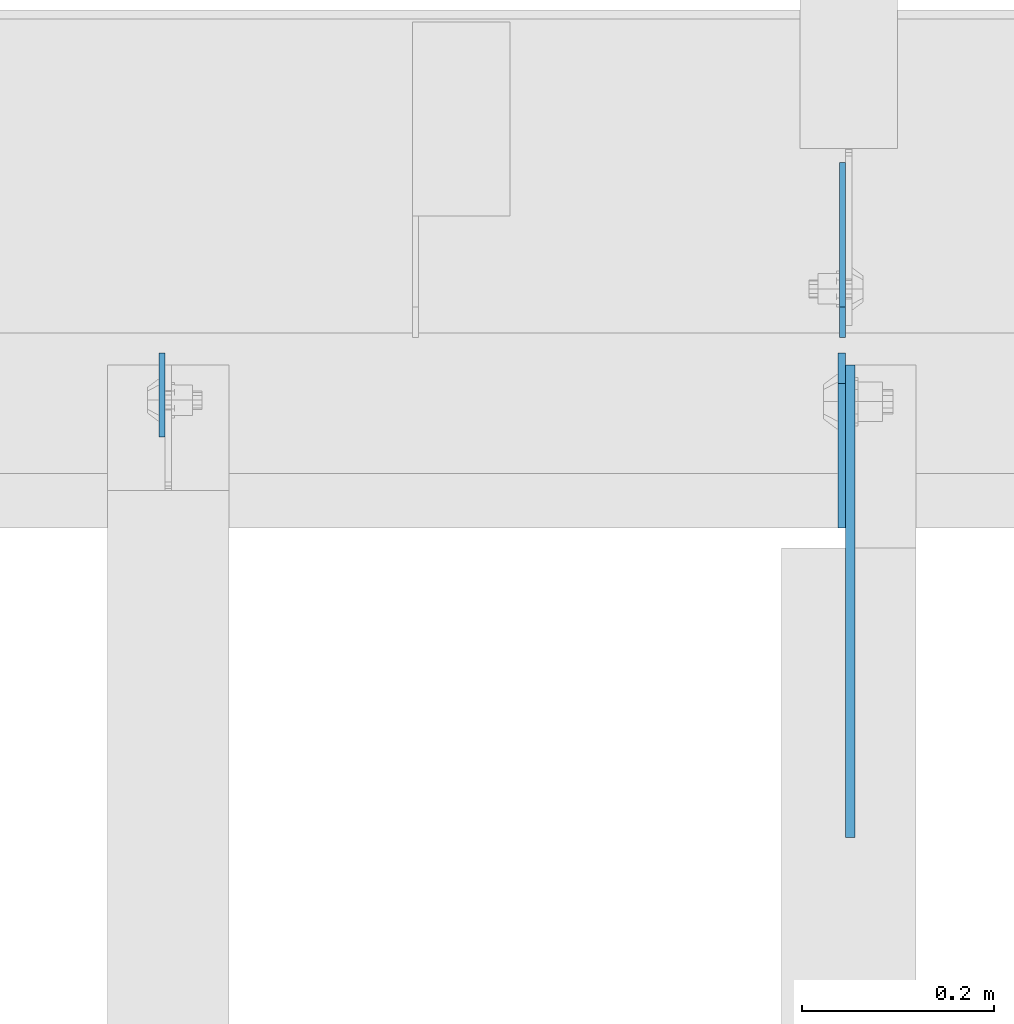
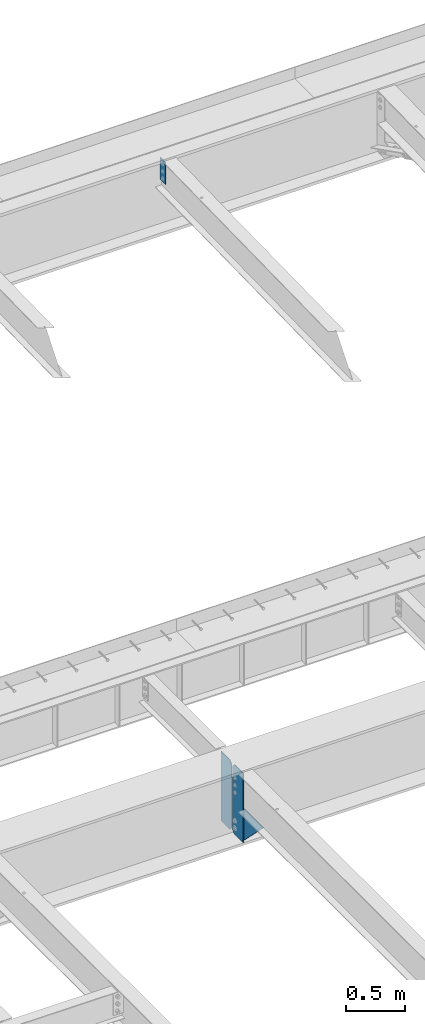
# One storey, part 1598 of 1763: 4 plates, 3 elements without a shape of their own.
"""IFC2X3 building model written with IfcOpenShell, lengths in millimetres."""

from ifc_helpers import new_model, si_unit, frame, origin_with_axes, place, context, subcontext, project, spatial, faceted_brep, material, type_object, element, aggregate, save


model = new_model("IFC2X3")

# Units and contexts
model_context = context("Model", 3, precision=1e-05, world=origin_with_axes())
body_context = subcontext(model_context, "Body", "Model", "MODEL_VIEW")
ifc_project = project(units=[si_unit("LENGTHUNIT", "METRE", prefix="MILLI"), si_unit("AREAUNIT", "SQUARE_METRE"), si_unit("VOLUMEUNIT", "CUBIC_METRE"), si_unit("MASSUNIT", "GRAM", prefix="KILO"), si_unit("TIMEUNIT", "SECOND"), si_unit("PLANEANGLEUNIT", "RADIAN"), si_unit("SOLIDANGLEUNIT", "STERADIAN"), si_unit("THERMODYNAMICTEMPERATUREUNIT", "DEGREE_CELSIUS"), si_unit("LUMINOUSINTENSITYUNIT", "LUMEN")], contexts=[model_context])

# Site, building, storey
site_placement = place(None, origin_with_axes())
site = spatial("IfcSite", under=ifc_project, at=site_placement, CompositionType="ELEMENT")
building_placement = place(site_placement, origin_with_axes())
building = spatial("IfcBuilding", under=site, at=building_placement, Name="Undefined", CompositionType="ELEMENT")
storey_placement = place(building_placement, origin_with_axes())
storey = spatial("IfcBuildingStorey", under=building, at=storey_placement, Name="Undefined", CompositionType="ELEMENT", Elevation=0.0)

# Assembly, plates
assembly_1_placement = place(storey_placement, origin_with_axes())
assembly_1 = element("IfcElementAssembly", 1, at=assembly_1_placement, inside=storey, Name="BEAM", AssemblyPlace="NOTDEFINED", PredefinedType="RIGID_FRAME")
ifc_material = material(Name="STEEL/A36")
plate_type_1 = type_object("IfcPlateType", PredefinedType="NOTDEFINED")
plate_1_placement = place(assembly_1_placement, frame((-82420.3206070794, 52128.7375, 4448.175), z_axis=(0.0, 0.0, 1.0), x_axis=(0.0, 1.0, 0.0)))
plate_1 = element("IfcPlate", 2, at=plate_1_placement, type_object=plate_type_1, material=ifc_material, Name="PLATE", context=body_context, shape_type="Brep", body=[
    faceted_brep([(0.0, -3.17500000000291, 31.75), (0.0, -3.17500000000291, 687.387512207031), (0.0, 3.17500000000291, 687.387512207031), (0.0, 3.17500000000291, 31.75), (31.75, -3.17500000000291, 719.137512207031), (31.75, 3.17500000000291, 719.137512207031), (182.5625, -3.17500000000291, 719.137512207031), (182.5625, 3.17500000000291, 719.137512207031), (182.5625, -3.17500000000291, 0.0), (182.5625, 3.17500000000291, 0.0), (31.7499999999036, -3.17499999997381, 9.42916855706244e-11), (31.7499999998854, 3.17500000000291, 9.42916855706244e-11)], [[[0, 1, 2, 3]], [[1, 4, 5, 2]], [[4, 6, 7, 5]], [[6, 8, 9, 7]], [[8, 10, 11, 9]], [[10, 0, 3, 11]], [[5, 7, 9, 11, 3, 2]], [[10, 8, 6, 4, 1, 0]]]),
])
plate_type_2 = type_object("IfcPlateType", PredefinedType="NOTDEFINED")
plate_2_placement = place(assembly_1_placement, frame((-82421.1153570965, 52112.8625, 4448.175), z_axis=(0.0, 0.0, 1.0), x_axis=(0.0, -1.0, 0.0)))
plate_2 = element("IfcPlate", 3, at=plate_2_placement, type_object=plate_type_2, material=ifc_material, Name="PLATE", context=body_context, shape_type="Brep", body=[
    faceted_brep([(0.0, -3.96899999999732, 31.75), (0.0, -3.96899999999732, 687.387512207031), (0.0, 3.96899999999732, 687.387512207031), (0.0, 3.96899999999732, 31.75), (31.75, -3.96899999999732, 719.137512207031), (31.75, 3.96899999999732, 719.137512207031), (182.5625, -3.96899999999732, 719.137512207031), (182.5625, 3.96899999999732, 719.137512207031), (182.5625, -3.96899999999732, 0.0), (182.5625, 3.96899999999732, 0.0), (31.75, -3.96899999999732, 0.0), (31.75, 3.96899999999732, 0.0)], [[[0, 1, 2, 3]], [[1, 4, 5, 2]], [[4, 6, 7, 5]], [[6, 8, 9, 7]], [[8, 10, 11, 9]], [[10, 0, 3, 11]], [[5, 7, 9, 11, 3, 2]], [[10, 8, 6, 4, 1, 0]]]),
])
aggregate(assembly_1, [plate_1, plate_2])

# Assembly, plate
assembly_2_placement = place(storey_placement, origin_with_axes())
assembly_2 = element("IfcElementAssembly", 4, at=assembly_2_placement, inside=storey, Name="BEAM", AssemblyPlace="NOTDEFINED", PredefinedType="RIGID_FRAME")
plate_type_3 = type_object("IfcPlateType", PredefinedType="NOTDEFINED")
plate_3_placement = place(assembly_2_placement, frame((-82412.3831070794, 51930.3004272461, 4794.2499684514), z_axis=(0.0, 0.0, -1.0), x_axis=(0.0, -1.0, 0.0)))
plate_3 = element("IfcPlate", 5, at=plate_3_placement, type_object=plate_type_3, material=ifc_material, Name="PLATE", context=body_context, shape_type="Brep", body=[
    faceted_brep([(0.0, -4.76249999999982, 0.0), (-169.862075805664, -4.76249999999709, 6.30279828328639e-10), (-169.862075805664, 4.76249999999709, 6.30279828328639e-10), (0.0, 4.76249999999982, 0.0), (-169.862091064453, -4.76249999999709, 323.002471923828), (-169.862091064453, 4.76249999999709, 323.002471923828), (6.38101482763886e-09, -4.76249999999709, 323.002471923828), (6.38101482763886e-09, 4.76249999999709, 323.002471923828), (322.262145996094, -4.76249999999709, -1.15778675535694e-09), (322.262145996094, 4.76249999999709, -1.15778675535694e-09)], [[[0, 1, 2, 3]], [[1, 4, 5, 2]], [[4, 6, 7, 5]], [[6, 8, 9, 7]], [[8, 0, 3, 9]], [[5, 7, 9, 3, 2]], [[8, 6, 4, 1, 0]]]),
])
aggregate(assembly_2, [plate_3])

assembly_3_placement = place(storey_placement, origin_with_axes())
assembly_3 = element("IfcElementAssembly", 6, at=assembly_3_placement, inside=storey, Name="BEAM", AssemblyPlace="NOTDEFINED", PredefinedType="RIGID_FRAME")
plate_type_4 = type_object("IfcPlateType", PredefinedType="NOTDEFINED")
plate_4_placement = place(assembly_3_placement, frame((-83129.1015594126, 52112.8625002128, 11684.3836745184), z_axis=(0.0, -1.0, 0.0), x_axis=(0.0, 0.0, -1.0)))
plate_4 = element("IfcPlate", 7, at=plate_4_placement, type_object=plate_type_4, material=ifc_material, Name="PLATE", context=body_context, shape_type="Brep", body=[
    faceted_brep([(1.81898940354586e-12, -3.17500000000291, 0.0), (0.0, -3.17500000000291, 87.3125), (0.0, 3.17500000000291, 87.3125), (-1.81898940354586e-12, 3.17499999997381, 0.0), (228.600006103516, -3.17500000000291, 87.3125), (228.600006103516, 3.17500000000291, 87.3125), (228.600006103516, -3.17500000001019, -7.27595761418343e-12), (228.600006103516, 3.17499999999563, -7.27595761418343e-12)], [[[0, 1, 2, 3]], [[1, 4, 5, 2]], [[4, 6, 7, 5]], [[6, 0, 3, 7]], [[5, 7, 3, 2]], [[6, 4, 1, 0]]]),
])
aggregate(assembly_3, [plate_4])

save(model, "model.ifc")
